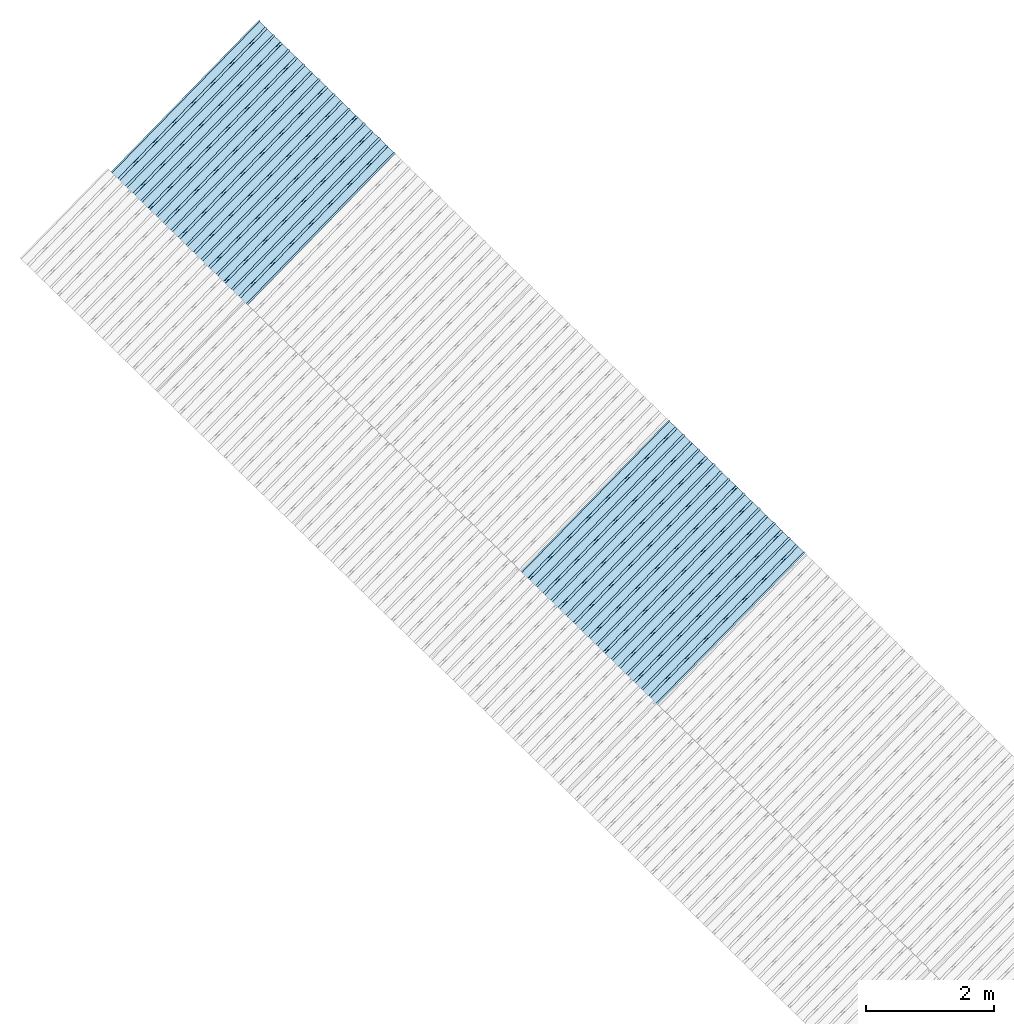
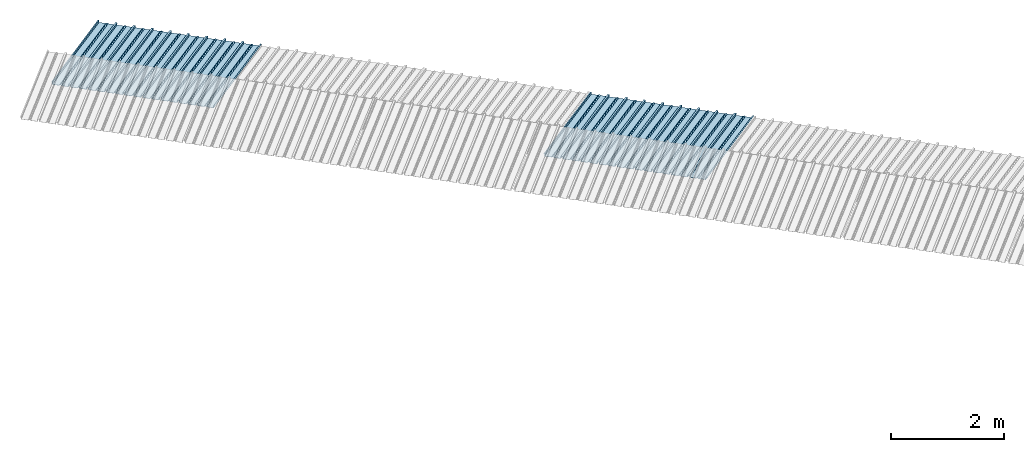
# One storey, part 8 of 8: 2 plates, 1 element without a shape of its own.
"""IFC4 building model written with IfcOpenShell, lengths in metres."""

from ifc_helpers import new_model, entity, si_unit, converted_unit, direction, frame, origin, place, context, subcontext, project, spatial, line, arc, indexed_curve, outline, extrude, source, transform, mapped, material, type_object, type_shapes, element, aggregate, save


model = new_model("IFC4")

# Units and contexts
model_context = context("Model", 3, precision=1e-05, world=origin(), true_north=direction((6.123233995736766e-17, 1.0)))
body_context = subcontext(model_context, "Body", "Model", "MODEL_VIEW")
ifc_project = project(units=[si_unit("LENGTHUNIT", "METRE"), si_unit("AREAUNIT", "SQUARE_METRE"), si_unit("VOLUMEUNIT", "CUBIC_METRE"), converted_unit("PLANEANGLEUNIT", "DEGREE", entity("IfcPlaneAngleMeasure", 0.017453292519943278), si_unit("PLANEANGLEUNIT", "RADIAN"), dimensions=[0, 0, 0, 0, 0, 0, 0])], contexts=[model_context])

# Site, building, storey
site_placement = place(None, frame((0.0, 0.0, 0.0), z_axis=(0.0, 0.0, 1.0), x_axis=(0.7160934825303189, -0.6980043870045516, 0.0)))
site = spatial("IfcSite", under=ifc_project, at=site_placement, CompositionType="ELEMENT")
building_placement = place(site_placement, origin())
building = spatial("IfcBuilding", under=site, at=building_placement, CompositionType="ELEMENT")
storey_placement = place(building_placement, frame((0.0, 0.0, -1.24)))
storey = spatial("IfcBuildingStorey", under=building, at=storey_placement, Name="Livello 5", CompositionType="ELEMENT", Elevation=-1.24)

# Roof, plates
curtain_wall_type = type_object("IfcCurtainWallType", Name="Vetrata Copertura 2", PredefinedType="NOTDEFINED")
roof_placement = place(storey_placement, frame((0.0, 0.0, 1.24)))
roof = element("IfcRoof", 1, at=roof_placement, inside=storey, type_object=curtain_wall_type, Name="Vetrata Copertura 2", ObjectType="Vetrata Copertura 2", PredefinedType="SHED_ROOF")
ifc_material = material(Name="Default")
plate_type_1 = type_object("IfcPlateType", Name="Pannello copertura:Pannello copertura", PredefinedType="CURTAIN_PANEL", material=ifc_material)
shared_shape_1 = source(origin(), body_context, "Body", "SweptSolid", [
    extrude(outline(indexed_curve([(1.339910560042256, -0.015785714285718594), (1.4699105600422562, -0.015785714285719003), (1.4699105600422562, 0.024214285714281004), (1.494919197675959, 0.02421428571428092), (1.494919197675959, 0.027214285714280917), (1.466910560042256, 0.027214285714281014), (1.466910560042256, -0.012785714285718995), (1.3417510978483753, -0.012785714285718492), (1.3199105600422556, 4.9134324369942785e-05), (1.2980700222361363, -0.012785714285718328), (1.1729105600422558, -0.01278571428571804), (1.1729105600422558, 0.02721428571428197), (1.136910560042256, 0.027214285714282097), (1.136910560042256, -0.012785714285717937), (1.0117510978483748, -0.01278571428571754), (0.9899105600422554, 4.913432437100935e-05), (0.968070022236136, -0.01278571428571726), (0.8429105600422558, -0.012785714285716971), (0.842910560042256, 0.027214285714283023), (0.8069105600422554, 0.027214285714283144), (0.8069105600422554, -0.01278571428571687), (0.6817510978483748, -0.012785714285716475), (0.6599105600422555, 4.9134324372075926e-05), (0.6380700222361361, -0.012785714285716196), (0.5129105600422553, -0.012785714285715915), (0.5129105600422554, 0.027214285714284105), (0.47691056004225557, 0.027214285714284227), (0.47691056004225557, -0.012785714285715804), (0.3517510978483749, -0.012785714285715427), (0.32991056004225544, 4.9134324373142496e-05), (0.3080700222361361, -0.012785714285715127), (0.18291056004225528, -0.012785714285714848), (0.18291056004225553, 0.027214285714285157), (0.1469105600422553, 0.02721428571428528), (0.14691056004225533, -0.012785714285714738), (0.021751097848374697, -0.01278571428571434), (-8.943995774469983e-05, 4.913432437420907e-05), (-0.021929977763864118, -0.01278571428571406), (-0.1470894399577447, -0.012785714285713783), (-0.14708943995774473, 0.02721428571428624), (-0.18308943995774493, 0.027214285714286364), (-0.1830894399577449, -0.012785714285713672), (-0.30824890215162537, -0.012785714285713215), (-0.33008943995774487, 4.9134324375275644e-05), (-0.3519299777638641, -0.012785714285712995), (-0.47708943995774494, -0.012785714285712714), (-0.4770894399577447, 0.02721428571428729), (-0.5130894399577449, 0.02721428571428741), (-0.5130894399577449, -0.012785714285712603), (-0.6382489021516256, -0.012785714285712207), (-0.6600894399577448, 4.9134324376342214e-05), (-0.6819299777638644, -0.012785714285711926), (-0.8070894399577453, -0.012785714285711647), (-0.807089439957745, 0.027214285714288373), (-0.843089439957745, 0.027214285714288494), (-0.8430894399577447, -0.012785714285711538), (-0.968248902151626, -0.012785714285711083), (-0.9900894399577453, 4.9134324377408785e-05), (-1.0119299777638646, -0.012785714285710861), (-1.1370894399577456, -0.012785714285710582), (-1.1370894399577451, 0.02721428571428942), (-1.1730894399577452, 0.027214285714289545), (-1.1730894399577454, -0.012785714285710473), (-1.2982489021516257, -0.012785714285710093), (-1.3200894399577452, 4.9134324378475355e-05), (-1.3419299777638647, -0.012785714285709794), (-1.4670894399577457, -0.012785714285709513), (-1.4670894399577454, 0.027214285714290503), (-1.490089439957745, 0.027214285714290586), (-1.490089439957745, 0.024214285714290556), (-1.4700894399577447, 0.02421428571429049), (-1.4700894399577449, -0.015785714285709514), (-1.3400894399577452, -0.015785714285709924), (-1.3200894399577452, -0.0029508656756215236), (-1.3000894399577452, -0.015785714285710063), (-1.170089439957745, -0.015785714285710472), (-1.1700894399577453, 0.024214285714289543), (-1.140089439957745, 0.02421428571428944), (-1.1400894399577455, -0.015785714285710583), (-1.0100894399577454, -0.015785714285710992), (-0.9900894399577453, -0.00295086567562259), (-0.9700894399577453, -0.015785714285711128), (-0.8400894399577448, -0.01578571428571154), (-0.8400894399577451, 0.024214285714288453), (-0.8100894399577452, 0.024214285714288356), (-0.8100894399577452, -0.015785714285711648), (-0.6800894399577451, -0.015785714285712012), (-0.6600894399577448, -0.0029508656756236573), (-0.6400894399577448, -0.015785714285712196), (-0.5100894399577451, -0.015785714285712606), (-0.5100894399577451, 0.024214285714287406), (-0.4800894399577449, 0.024214285714287305), (-0.4800894399577449, -0.015785714285712713), (-0.350089439957745, -0.01578571428571316), (-0.33008943995774487, -0.0029508656756247237), (-0.31008943995774485, -0.01578571428571326), (-0.1800894399577448, -0.015785714285713674), (-0.1800894399577448, 0.024214285714286323), (-0.1500894399577446, 0.02421428571428622), (-0.15008943995774485, -0.015785714285713782), (-0.020089439957744877, -0.015785714285714264), (-8.943995774473269e-05, -0.00295086567562579), (0.01991056004225521, -0.015785714285714323), (0.14991056004225545, -0.01578571428571474), (0.14991056004225542, 0.024214285714285272), (0.17991056004225567, 0.02421428571428517), (0.1799105600422554, -0.01578571428571485), (0.30991056004225526, -0.01578571428571532), (0.32991056004225544, -0.0029508656756268565), (0.3499105600422554, -0.015785714285715395), (0.47991056004225535, -0.015785714285715804), (0.47991056004225535, 0.02421428571428419), (0.5099105600422553, 0.02421428571428409), (0.5099105600422552, -0.015785714285715916), (0.6399105600422554, -0.015785714285716325), (0.6599105600422555, -0.002950865675627923), (0.6799105600422555, -0.01578571428571646), (0.8099105600422557, -0.015785714285716873), (0.8099105600422557, 0.02421428571428314), (0.8399105600422555, 0.02421428571428304), (0.8399105600422554, -0.015785714285716974), (0.9699105600422554, -0.015785714285717393), (0.9899105600422554, -0.0029508656756289894), (1.0099105600422555, -0.01578571428571753), (1.1399105600422557, -0.015785714285717938), (1.1399105600422557, 0.024214285714282077), (1.169910560042256, 0.024214285714281972), (1.1699105600422557, -0.01578571428571804), (1.2999105600422558, -0.01578571428571846), (1.3199105600422558, -0.0029508656756300567)], segments=[line(1, 2, 3, 4, 5, 6, 7, 8), arc(8, 9, 10), line(10, 11, 12, 13, 14, 15), arc(15, 16, 17), line(17, 18, 19, 20, 21, 22), arc(22, 23, 24), line(24, 25, 26, 27, 28, 29), arc(29, 30, 31), line(31, 32, 33, 34, 35, 36), arc(36, 37, 38), line(38, 39, 40, 41, 42, 43), arc(43, 44, 45), line(45, 46, 47, 48, 49, 50), arc(50, 51, 52), line(52, 53, 54, 55, 56, 57), arc(57, 58, 59), line(59, 60, 61, 62, 63, 64), arc(64, 65, 66), line(66, 67, 68, 69, 70, 71, 72, 73), arc(73, 74, 75), line(75, 76, 77, 78, 79, 80), arc(80, 81, 82), line(82, 83, 84, 85, 86, 87), arc(87, 88, 89), line(89, 90, 91, 92, 93, 94), arc(94, 95, 96), line(96, 97, 98, 99, 100, 101), arc(101, 102, 103), line(103, 104, 105, 106, 107, 108), arc(108, 109, 110), line(110, 111, 112, 113, 114, 115), arc(115, 116, 117), line(117, 118, 119, 120, 121, 122), arc(122, 123, 124), line(124, 125, 126, 127, 128, 129), arc(129, 130, 1)], self_intersect=False)), frame((8.080232403624576e-05, -0.015785714285719014, 0.0), z_axis=(0.0, 0.0, -1.0), x_axis=(1.0, 0.0, 0.0)), (0.0, 0.0, -1.0), 3.472878469300717),
])
type_shapes(plate_type_1, [shared_shape_1])
plate_1_placement = place(roof_placement, frame((-26.139747038249816, -4.997561216564662, -1.6240000000000003), z_axis=(0.0, 0.9632563788424056, -0.26858359707810914), x_axis=(1.0, 0.0, 0.0)))
plate_1 = element("IfcPlate", 2, at=plate_1_placement, type_object=plate_type_1, material=ifc_material, Name="Pannello copertura:Pannello copertura", ObjectType="Pannello copertura:Pannello copertura", PredefinedType="CURTAIN_PANEL", context=body_context, shape_type="MappedRepresentation", body=[
    mapped(shared_shape_1, transform((0.0, 0.0, 0.0), scale=1.0)),
])
plate_type_2 = type_object("IfcPlateType", Name="Pannello copertura:Pannello copertura", PredefinedType="CURTAIN_PANEL", material=ifc_material)
shared_shape_2 = source(origin(), body_context, "Body", "SweptSolid", [
    extrude(outline(indexed_curve([(1.339910560042256, -0.015785714285718594), (1.4699105600422562, -0.015785714285719003), (1.4699105600422562, 0.024214285714281004), (1.494919197675959, 0.02421428571428092), (1.494919197675959, 0.027214285714280917), (1.466910560042256, 0.027214285714281014), (1.466910560042256, -0.012785714285718995), (1.3417510978483753, -0.012785714285718492), (1.3199105600422556, 4.9134324369942785e-05), (1.2980700222361363, -0.012785714285718328), (1.1729105600422558, -0.01278571428571804), (1.1729105600422558, 0.02721428571428197), (1.136910560042256, 0.027214285714282097), (1.136910560042256, -0.012785714285717937), (1.0117510978483748, -0.01278571428571754), (0.9899105600422554, 4.913432437100935e-05), (0.968070022236136, -0.01278571428571726), (0.8429105600422558, -0.012785714285716971), (0.842910560042256, 0.027214285714283023), (0.8069105600422554, 0.027214285714283144), (0.8069105600422554, -0.01278571428571687), (0.6817510978483748, -0.012785714285716475), (0.6599105600422555, 4.9134324372075926e-05), (0.6380700222361361, -0.012785714285716196), (0.5129105600422553, -0.012785714285715915), (0.5129105600422554, 0.027214285714284105), (0.47691056004225557, 0.027214285714284227), (0.47691056004225557, -0.012785714285715804), (0.3517510978483749, -0.012785714285715427), (0.32991056004225544, 4.9134324373142496e-05), (0.3080700222361361, -0.012785714285715127), (0.18291056004225528, -0.012785714285714848), (0.18291056004225553, 0.027214285714285157), (0.1469105600422553, 0.02721428571428528), (0.14691056004225533, -0.012785714285714738), (0.021751097848374697, -0.01278571428571434), (-8.943995774469983e-05, 4.913432437420907e-05), (-0.021929977763864118, -0.01278571428571406), (-0.1470894399577447, -0.012785714285713783), (-0.14708943995774473, 0.02721428571428624), (-0.18308943995774493, 0.027214285714286364), (-0.1830894399577449, -0.012785714285713672), (-0.30824890215162537, -0.012785714285713215), (-0.33008943995774487, 4.9134324375275644e-05), (-0.3519299777638641, -0.012785714285712995), (-0.47708943995774494, -0.012785714285712714), (-0.4770894399577447, 0.02721428571428729), (-0.5130894399577449, 0.02721428571428741), (-0.5130894399577449, -0.012785714285712603), (-0.6382489021516256, -0.012785714285712207), (-0.6600894399577448, 4.9134324376342214e-05), (-0.6819299777638644, -0.012785714285711926), (-0.8070894399577453, -0.012785714285711647), (-0.807089439957745, 0.027214285714288373), (-0.843089439957745, 0.027214285714288494), (-0.8430894399577447, -0.012785714285711538), (-0.968248902151626, -0.012785714285711083), (-0.9900894399577453, 4.9134324377408785e-05), (-1.0119299777638646, -0.012785714285710861), (-1.1370894399577456, -0.012785714285710582), (-1.1370894399577451, 0.02721428571428942), (-1.1730894399577452, 0.027214285714289545), (-1.1730894399577454, -0.012785714285710473), (-1.2982489021516257, -0.012785714285710093), (-1.3200894399577452, 4.9134324378475355e-05), (-1.3419299777638647, -0.012785714285709794), (-1.4670894399577457, -0.012785714285709513), (-1.4670894399577454, 0.027214285714290503), (-1.490089439957745, 0.027214285714290586), (-1.490089439957745, 0.024214285714290556), (-1.4700894399577447, 0.02421428571429049), (-1.4700894399577449, -0.015785714285709514), (-1.3400894399577452, -0.015785714285709924), (-1.3200894399577452, -0.0029508656756215236), (-1.3000894399577452, -0.015785714285710063), (-1.170089439957745, -0.015785714285710472), (-1.1700894399577453, 0.024214285714289543), (-1.140089439957745, 0.02421428571428944), (-1.1400894399577455, -0.015785714285710583), (-1.0100894399577454, -0.015785714285710992), (-0.9900894399577453, -0.00295086567562259), (-0.9700894399577453, -0.015785714285711128), (-0.8400894399577448, -0.01578571428571154), (-0.8400894399577451, 0.024214285714288453), (-0.8100894399577452, 0.024214285714288356), (-0.8100894399577452, -0.015785714285711648), (-0.6800894399577451, -0.015785714285712012), (-0.6600894399577448, -0.0029508656756236573), (-0.6400894399577448, -0.015785714285712196), (-0.5100894399577451, -0.015785714285712606), (-0.5100894399577451, 0.024214285714287406), (-0.4800894399577449, 0.024214285714287305), (-0.4800894399577449, -0.015785714285712713), (-0.350089439957745, -0.01578571428571316), (-0.33008943995774487, -0.0029508656756247237), (-0.31008943995774485, -0.01578571428571326), (-0.1800894399577448, -0.015785714285713674), (-0.1800894399577448, 0.024214285714286323), (-0.1500894399577446, 0.02421428571428622), (-0.15008943995774485, -0.015785714285713782), (-0.020089439957744877, -0.015785714285714264), (-8.943995774473269e-05, -0.00295086567562579), (0.01991056004225521, -0.015785714285714323), (0.14991056004225545, -0.01578571428571474), (0.14991056004225542, 0.024214285714285272), (0.17991056004225567, 0.02421428571428517), (0.1799105600422554, -0.01578571428571485), (0.30991056004225526, -0.01578571428571532), (0.32991056004225544, -0.0029508656756268565), (0.3499105600422554, -0.015785714285715395), (0.47991056004225535, -0.015785714285715804), (0.47991056004225535, 0.02421428571428419), (0.5099105600422553, 0.02421428571428409), (0.5099105600422552, -0.015785714285715916), (0.6399105600422554, -0.015785714285716325), (0.6599105600422555, -0.002950865675627923), (0.6799105600422555, -0.01578571428571646), (0.8099105600422557, -0.015785714285716873), (0.8099105600422557, 0.02421428571428314), (0.8399105600422555, 0.02421428571428304), (0.8399105600422554, -0.015785714285716974), (0.9699105600422554, -0.015785714285717393), (0.9899105600422554, -0.0029508656756289894), (1.0099105600422555, -0.01578571428571753), (1.1399105600422557, -0.015785714285717938), (1.1399105600422557, 0.024214285714282077), (1.169910560042256, 0.024214285714281972), (1.1699105600422557, -0.01578571428571804), (1.2999105600422558, -0.01578571428571846), (1.3199105600422558, -0.0029508656756300567)], segments=[line(1, 2, 3, 4, 5, 6, 7, 8), arc(8, 9, 10), line(10, 11, 12, 13, 14, 15), arc(15, 16, 17), line(17, 18, 19, 20, 21, 22), arc(22, 23, 24), line(24, 25, 26, 27, 28, 29), arc(29, 30, 31), line(31, 32, 33, 34, 35, 36), arc(36, 37, 38), line(38, 39, 40, 41, 42, 43), arc(43, 44, 45), line(45, 46, 47, 48, 49, 50), arc(50, 51, 52), line(52, 53, 54, 55, 56, 57), arc(57, 58, 59), line(59, 60, 61, 62, 63, 64), arc(64, 65, 66), line(66, 67, 68, 69, 70, 71, 72, 73), arc(73, 74, 75), line(75, 76, 77, 78, 79, 80), arc(80, 81, 82), line(82, 83, 84, 85, 86, 87), arc(87, 88, 89), line(89, 90, 91, 92, 93, 94), arc(94, 95, 96), line(96, 97, 98, 99, 100, 101), arc(101, 102, 103), line(103, 104, 105, 106, 107, 108), arc(108, 109, 110), line(110, 111, 112, 113, 114, 115), arc(115, 116, 117), line(117, 118, 119, 120, 121, 122), arc(122, 123, 124), line(124, 125, 126, 127, 128, 129), arc(129, 130, 1)], self_intersect=False)), frame((8.080232403624576e-05, -0.015785714285719014, 0.0), z_axis=(0.0, 0.0, -1.0), x_axis=(1.0, 0.0, 0.0)), (0.0, 0.0, -1.0), 3.472878469300717),
])
type_shapes(plate_type_2, [shared_shape_2])
plate_2_placement = place(roof_placement, frame((-17.17486689694045, -4.997561216564662, -1.6240000000000003), z_axis=(0.0, 0.9632563788424056, -0.26858359707810914), x_axis=(1.0, 0.0, 0.0)))
plate_2 = element("IfcPlate", 3, at=plate_2_placement, type_object=plate_type_2, material=ifc_material, Name="Pannello copertura:Pannello copertura", ObjectType="Pannello copertura:Pannello copertura", PredefinedType="CURTAIN_PANEL", context=body_context, shape_type="MappedRepresentation", body=[
    mapped(shared_shape_2, transform((0.0, 0.0, 0.0), scale=1.0)),
])
aggregate(roof, [plate_1, plate_2])

save(model, "model.ifc")
